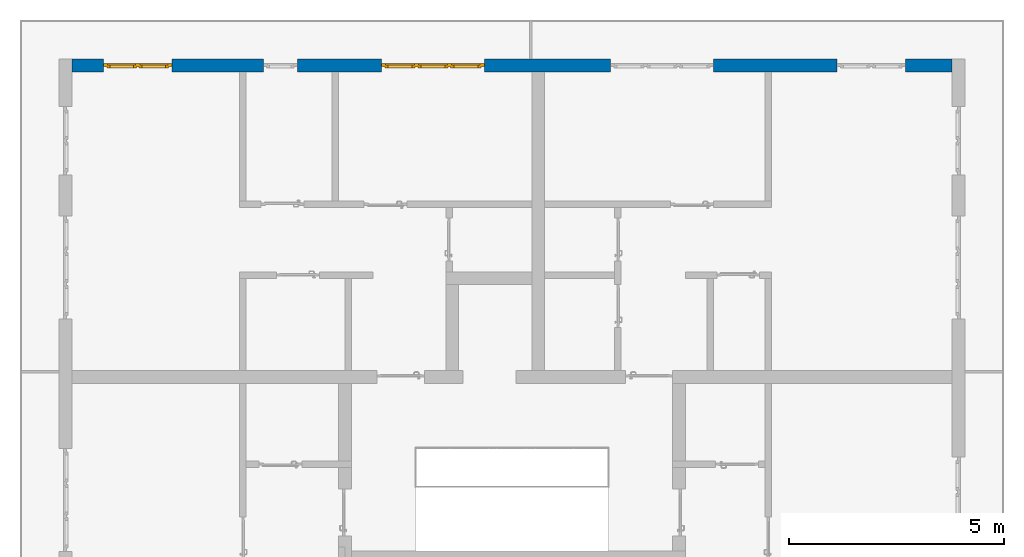
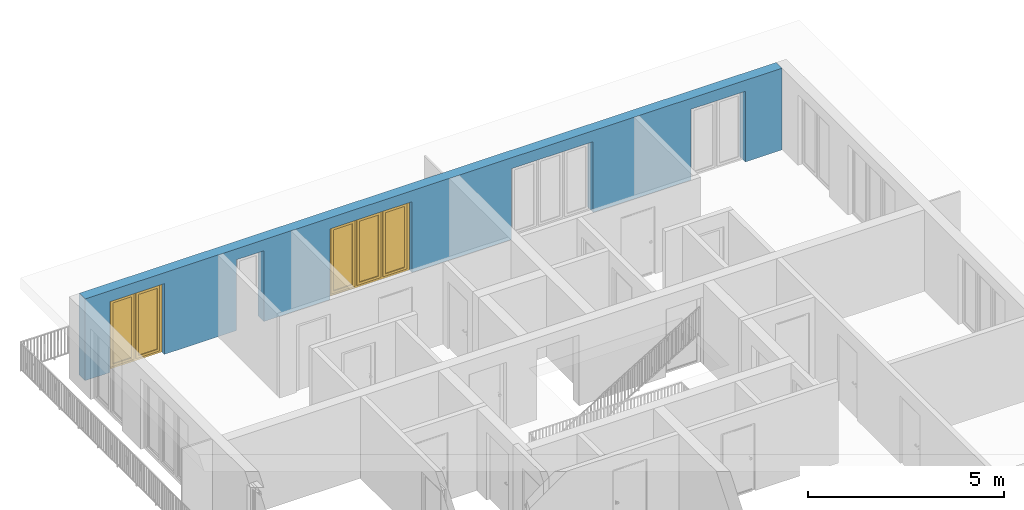
# One storey, part 26 of 54: 2 windows, 1 wall, 5 openings.
"""IFC4 building model written with IfcOpenShell, lengths in metres."""

from ifc_helpers import new_model, entity, si_unit, converted_unit, derived_unit, direction, frame, origin_with_axes, place, context, subcontext, project, spatial, polygons, source, transform, mapped, material, type_object, element, fill, save


model = new_model("IFC4")

# Units and contexts
model_context = context("Model", 3, precision=1e-05, world=origin_with_axes(), true_north=direction((0.0, 1.0)))
body_context = subcontext(model_context, "Body", "Model", "MODEL_VIEW")
ifc_project = project(units=[si_unit("LENGTHUNIT", "METRE"), si_unit("AREAUNIT", "SQUARE_METRE"), si_unit("VOLUMEUNIT", "CUBIC_METRE"), converted_unit("PLANEANGLEUNIT", "DEGREE", entity("IfcPlaneAngleMeasure", 0.0174532925199), si_unit("PLANEANGLEUNIT", "RADIAN"), dimensions=[0, 0, 0, 0, 0, 0, 0]), converted_unit("TIMEUNIT", "Year", entity("IfcTimeMeasure", 31556926.0), si_unit("TIMEUNIT", "SECOND"), dimensions=[0, 0, 1, 0, 0, 0, 0]), si_unit("MASSUNIT", "GRAM", prefix="KILO"), si_unit("THERMODYNAMICTEMPERATUREUNIT", "DEGREE_CELSIUS"), si_unit("LUMINOUSINTENSITYUNIT", "LUMEN"), si_unit("ENERGYUNIT", "JOULE", prefix="MEGA"), derived_unit("THERMALCONDUCTANCEUNIT", [(si_unit("POWERUNIT", "WATT"), 1), (si_unit("LENGTHUNIT", "METRE"), -1), (si_unit("THERMODYNAMICTEMPERATUREUNIT", "KELVIN"), -1)]), derived_unit("SPECIFICHEATCAPACITYUNIT", [(si_unit("ENERGYUNIT", "JOULE"), 1), (si_unit("MASSUNIT", "GRAM", prefix="KILO"), -1), (si_unit("THERMODYNAMICTEMPERATUREUNIT", "KELVIN"), -1)]), derived_unit("MASSDENSITYUNIT", [(si_unit("MASSUNIT", "GRAM", prefix="KILO"), 1), (si_unit("VOLUMEUNIT", "CUBIC_METRE"), -1)])], contexts=[model_context])

# Site, building, storey
site_placement = place(None, origin_with_axes())
site = spatial("IfcSite", under=ifc_project, at=site_placement, CompositionType="ELEMENT")
building_placement = place(site_placement, origin_with_axes())
building = spatial("IfcBuilding", under=site, at=building_placement, CompositionType="ELEMENT")
storey_placement = place(building_placement, frame((0.0, 0.0, 6.29), z_axis=(0.0, 0.0, 1.0), x_axis=(1.0, 0.0, 0.0)))
storey = spatial("IfcBuildingStorey", under=building, at=storey_placement, Name="2. Geschoss", CompositionType="ELEMENT", Elevation=6.29)

# Wall, openings, windows
ifc_material = material()
wall_type = type_object("IfcWallType", Name="300", PredefinedType="NOTDEFINED")
wall_placement = place(storey_placement, frame((-11.7421993804, 8.92118776896, 0.0), z_axis=(0.0, 0.0, 1.0), x_axis=(1.0, 0.0, 0.0)))
wall = element("IfcWall", 1, at=wall_placement, inside=storey, type_object=wall_type, material=ifc_material, Name="Wand-001", PredefinedType="NOTDEFINED", context=body_context, shape_type="Tessellation", body=[
    polygons([(15.23, -0.1, 0.0), (15.23, -0.3, 0.0), (15.23, -0.3, 2.2), (15.23, 0.0, 2.2), (15.23, 0.0, 0.0), (18.102139809, 0.0, 0.0), (18.102139809, -0.3, 0.0), (18.102139809, -0.3, 2.2), (19.702139809, -0.3, 2.2), (19.702139809, -0.3, 0.0), (20.78, -0.3, 0.0), (20.78, -0.3, 2.54), (0.3, -0.3, 2.54), (0.3, -0.3, 0.0), (1.0288518641, -0.3, 0.0), (1.0288518641, -0.3, 2.2), (2.6288518641, -0.3, 2.2), (2.6288518641, -0.3, 0.0), (4.75, -0.3, 0.0), (4.75, -0.3, 2.2), (5.55, -0.3, 2.2), (5.55, -0.3, 0.0), (7.50089858046, -0.3, 0.0), (7.50089858046, -0.3, 2.2), (9.90089858046, -0.3, 2.2), (9.90089858046, -0.3, 0.0), (12.83, -0.3, 0.0), (12.83, -0.3, 2.2), (12.83, 0.0, 2.2), (12.83, 0.0, 0.0), (9.90089858046, 0.0, 0.0), (9.90089858046, 0.0, 2.2), (7.50089858046, 0.0, 2.2), (7.50089858046, 0.0, 0.0), (5.55, 0.0, 0.0), (5.55, 0.0, 2.2), (4.75, 0.0, 2.2), (4.75, 0.0, 0.0), (2.6288518641, 0.0, 0.0), (2.6288518641, 0.0, 2.2), (1.0288518641, 0.0, 2.2), (1.0288518641, 0.0, 0.0), (0.3, 0.0, 0.0), (0.3, 0.0, 2.54), (20.78, 0.0, 2.54), (20.78, 0.0, 0.0), (19.702139809, 0.0, 0.0), (19.702139809, 0.0, 2.2), (18.102139809, 0.0, 2.2), (12.83, -0.1, 0.0)], [[[1, 2, 3, 4, 5]], [[2, 1, 5, 6, 7]], [[3, 2, 7, 8, 9, 10, 11, 12, 13, 14, 15, 16, 17, 18, 19, 20, 21, 22, 23, 24, 25, 26, 27, 28]], [[4, 3, 28, 29]], [[6, 5, 4, 29, 30, 31, 32, 33, 34, 35, 36, 37, 38, 39, 40, 41, 42, 43, 44, 45, 46, 47, 48, 49]], [[6, 49, 8, 7]], [[8, 49, 48, 9]], [[48, 47, 10, 9]], [[46, 11, 10, 47]], [[12, 11, 46, 45]], [[45, 44, 13, 12]], [[44, 43, 14, 13]], [[15, 14, 43, 42]], [[16, 15, 42, 41]], [[40, 17, 16, 41]], [[18, 17, 40, 39]], [[19, 18, 39, 38]], [[20, 19, 38, 37]], [[36, 21, 20, 37]], [[22, 21, 36, 35]], [[22, 35, 34, 23]], [[34, 33, 24, 23]], [[24, 33, 32, 25]], [[32, 31, 26, 25]], [[50, 27, 26, 31, 30]], [[28, 27, 50, 30, 29]]], closed=True),
])
opening_1_placement = place(wall_placement, frame((1.8288518641, 0.0, 0.0), z_axis=(0.0, 0.0, 1.0), x_axis=(1.0, 0.0, 0.0)))
opening_1 = element("IfcOpeningElement", 2, at=opening_1_placement, cuts=wall, Name="Fenster-001", context=body_context, identifier="Reference", shape_type="Tessellation", body=[
    polygons([(-0.8, -0.1, 0.0), (-0.8, -0.1, 2.2), (-0.8, 0.000999999999998, 2.2), (-0.8, 0.000999999999998, 0.0), (-0.8, -0.301, 0.0), (-0.8, -0.301, 2.2), (0.8, -0.1, 2.2), (0.8, 0.000999999999999, 2.2), (0.8, -0.301, 2.2), (0.8, 0.000999999999999, 0.0), (0.8, -0.1, 0.0), (0.8, -0.301, 0.0)], [[[1, 2, 3, 4]], [[2, 1, 5, 6]], [[7, 8, 3, 2, 6, 9]], [[8, 10, 4, 3]], [[1, 4, 10, 11, 12, 5]], [[6, 5, 12, 9]], [[7, 11, 10, 8]], [[11, 7, 9, 12]]], closed=True),
])
opening_2_placement = place(wall_placement, frame((8.70089858046, 0.0, 0.0), z_axis=(0.0, 0.0, 1.0), x_axis=(1.0, 0.0, 0.0)))
opening_2 = element("IfcOpeningElement", 3, at=opening_2_placement, cuts=wall, Name="Fenster-002", context=body_context, identifier="Reference", shape_type="Tessellation", body=[
    polygons([(-1.2, -0.1, 0.0), (-1.2, -0.1, 2.2), (-1.2, 0.000999999999999, 2.2), (-1.2, 0.000999999999999, 0.0), (-1.2, -0.301, 0.0), (-1.2, -0.301, 2.2), (1.2, -0.1, 2.2), (1.2, 0.001, 2.2), (1.2, -0.301, 2.2), (1.2, 0.001, 0.0), (1.2, -0.1, 0.0), (1.2, -0.301, 0.0)], [[[1, 2, 3, 4]], [[2, 1, 5, 6]], [[7, 8, 3, 2, 6, 9]], [[8, 10, 4, 3]], [[1, 4, 10, 11, 12, 5]], [[6, 5, 12, 9]], [[7, 11, 10, 8]], [[11, 7, 9, 12]]], closed=True),
])
opening_3_placement = place(wall_placement, frame((5.15, 0.0, 0.0), z_axis=(0.0, 0.0, 1.0), x_axis=(1.0, 0.0, 0.0)))
element("IfcOpeningElement", 4, at=opening_3_placement, cuts=wall, Name="Fenster-003", context=body_context, identifier="Reference", shape_type="Tessellation", body=[
    polygons([(-0.4, -0.1, 0.0), (-0.4, -0.1, 2.2), (-0.4, 0.001, 2.2), (-0.4, 0.001, 0.0), (-0.4, -0.301, 0.0), (-0.4, -0.301, 2.2), (0.4, -0.1, 2.2), (0.4, 0.001, 2.2), (0.4, -0.301, 2.2), (0.4, 0.001, 0.0), (0.4, -0.1, 0.0), (0.4, -0.301, 0.0)], [[[1, 2, 3, 4]], [[2, 1, 5, 6]], [[7, 8, 3, 2, 6, 9]], [[8, 10, 4, 3]], [[1, 4, 10, 11, 12, 5]], [[6, 5, 12, 9]], [[7, 11, 10, 8]], [[11, 7, 9, 12]]], closed=True),
])
opening_4_placement = place(wall_placement, frame((18.902139809, 0.0, 0.0), z_axis=(0.0, 0.0, 1.0), x_axis=(1.0, 0.0, 0.0)))
element("IfcOpeningElement", 5, at=opening_4_placement, cuts=wall, Name="Fenster-001", context=body_context, identifier="Reference", shape_type="Tessellation", body=[
    polygons([(-0.8, -0.1, 0.0), (-0.8, -0.1, 2.2), (-0.8, 0.001, 2.2), (-0.8, 0.001, 0.0), (-0.8, -0.301, 0.0), (-0.8, -0.301, 2.2), (0.8, -0.1, 2.2), (0.8, 0.001, 2.2), (0.8, -0.301, 2.2), (0.8, 0.001, 0.0), (0.8, -0.1, 0.0), (0.8, -0.301, 0.0)], [[[1, 2, 3, 4]], [[2, 1, 5, 6]], [[7, 8, 3, 2, 6, 9]], [[8, 10, 4, 3]], [[1, 4, 10, 11, 12, 5]], [[6, 5, 12, 9]], [[7, 11, 10, 8]], [[11, 7, 9, 12]]], closed=True),
])
opening_5_placement = place(wall_placement, frame((14.03, 0.0, 0.0), z_axis=(0.0, 0.0, 1.0), x_axis=(1.0, 0.0, 0.0)))
element("IfcOpeningElement", 6, at=opening_5_placement, cuts=wall, Name="Fenster-002", context=body_context, identifier="Reference", shape_type="Tessellation", body=[
    polygons([(-1.2, -0.1, 0.0), (-1.2, -0.1, 2.2), (-1.2, 0.001, 2.2), (-1.2, 0.001, 0.0), (-1.2, -0.301, 0.0), (-1.2, -0.301, 2.2), (1.2, -0.1, 2.2), (1.2, 0.001, 2.2), (1.2, -0.301, 2.2), (1.2, 0.001, 0.0), (1.2, -0.1, 0.0), (1.2, -0.301, 0.0)], [[[1, 2, 3, 4]], [[2, 1, 5, 6]], [[7, 8, 3, 2, 6, 9]], [[8, 10, 4, 3]], [[1, 4, 10, 11, 12, 5]], [[6, 5, 12, 9]], [[7, 11, 10, 8]], [[11, 7, 9, 12]]], closed=True),
])
window_type_1 = type_object("IfcWindowType", Name="2-1+1 26", PartitioningType="DOUBLE_PANEL_VERTICAL", PredefinedType="WINDOW")
shared_shape_1 = source(origin_with_axes(), body_context, "Body", "Tessellation", [
    polygons([(0.8, -0.07, 0.0), (0.7, -0.07, 0.1), (0.7, 0.0, 0.1), (0.8, 0.0, 0.0), (0.8, -0.07, 2.2), (0.7, -0.07, 2.1), (0.7, 0.0, 2.1), (0.8, 0.0, 2.2)], [[[1, 2, 3, 4]], [[1, 5, 6, 2]], [[2, 6, 7, 3]], [[4, 3, 7, 8]], [[5, 1, 4, 8]], [[6, 5, 8, 7]]], closed=True),
    polygons([(-0.8, -0.07, 0.0), (-0.8, -0.07, 2.2), (-0.8, 0.0, 2.2), (-0.8, 0.0, 0.0), (-0.7, -0.07, 0.1), (-0.7, -0.07, 2.1), (-0.7, 0.0, 2.1), (-0.7, 0.0, 0.1)], [[[1, 2, 3, 4]], [[1, 5, 6, 2]], [[2, 6, 7, 3]], [[4, 3, 7, 8]], [[5, 1, 4, 8]], [[6, 5, 8, 7]]], closed=True),
    polygons([(0.8, -0.07, 0.0), (-0.8, -0.07, 0.0), (-0.8, 0.0, 0.0), (0.8, 0.0, 0.0), (0.7, -0.07, 0.1), (0.05, -0.07, 0.1), (-0.05, -0.07, 0.1), (-0.7, -0.07, 0.1), (-0.7, 0.0, 0.1), (-0.05, 0.0, 0.1), (0.05, 0.0, 0.1), (0.7, 0.0, 0.1)], [[[1, 2, 3, 4]], [[1, 5, 6, 7, 8, 2]], [[2, 8, 9, 3]], [[4, 3, 9, 10, 11, 12]], [[5, 1, 4, 12]], [[6, 5, 12, 11]], [[7, 6, 11, 10]], [[8, 7, 10, 9]]], closed=True),
    polygons([(0.8, -0.07, 2.2), (0.7, -0.07, 2.1), (0.7, 0.0, 2.1), (0.8, 0.0, 2.2), (-0.8, -0.07, 2.2), (-0.7, -0.07, 2.1), (-0.05, -0.07, 2.1), (0.05, -0.07, 2.1), (0.05, 0.0, 2.1), (-0.05, 0.0, 2.1), (-0.7, 0.0, 2.1), (-0.8, 0.0, 2.2)], [[[1, 2, 3, 4]], [[1, 5, 6, 7, 8, 2]], [[2, 8, 9, 3]], [[4, 3, 9, 10, 11, 12]], [[5, 1, 4, 12]], [[6, 5, 12, 11]], [[7, 6, 11, 10]], [[8, 7, 10, 9]]], closed=True),
    polygons([(0.05, -0.07, 0.1), (-0.05, -0.07, 0.1), (-0.05, 0.0, 0.1), (0.05, 0.0, 0.1), (0.05, -0.07, 2.1), (-0.05, -0.07, 2.1), (-0.05, 0.0, 2.1), (0.05, 0.0, 2.1)], [[[1, 2, 3, 4]], [[1, 5, 6, 2]], [[2, 6, 7, 3]], [[4, 3, 7, 8]], [[5, 1, 4, 8]], [[6, 5, 8, 7]]], closed=True),
    polygons([(0.72, 0.0, 0.08), (0.65, 0.0, 0.15), (0.65, 0.03, 0.15), (0.72, 0.03, 0.08), (0.72, 0.0, 2.12), (0.65, 0.0, 2.05), (0.65, 0.03, 2.05), (0.72, 0.03, 2.12)], [[[1, 2, 3, 4]], [[1, 5, 6, 2]], [[2, 6, 7, 3]], [[4, 3, 7, 8]], [[5, 1, 4, 8]], [[6, 5, 8, 7]]], closed=True),
    polygons([(0.03, 0.0, 0.08), (0.03, 0.03, 0.08), (0.1, 0.03, 0.15), (0.1, 0.0, 0.15), (0.03, 0.0, 2.12), (0.03, 0.03, 2.12), (0.1, 0.03, 2.05), (0.1, 0.0, 2.05)], [[[1, 2, 3, 4]], [[5, 6, 2, 1]], [[2, 6, 7, 3]], [[4, 3, 7, 8]], [[1, 4, 8, 5]], [[8, 7, 6, 5]]], closed=True),
    polygons([(0.72, 0.0, 0.08), (0.03, 0.0, 0.08), (0.03, 0.03, 0.08), (0.72, 0.03, 0.08), (0.65, 0.0, 0.15), (0.1, 0.0, 0.15), (0.1, 0.03, 0.15), (0.65, 0.03, 0.15)], [[[1, 2, 3, 4]], [[1, 5, 6, 2]], [[2, 6, 7, 3]], [[4, 3, 7, 8]], [[5, 1, 4, 8]], [[6, 5, 8, 7]]], closed=True),
    polygons([(0.72, 0.0, 2.12), (0.72, 0.03, 2.12), (0.03, 0.03, 2.12), (0.03, 0.0, 2.12), (0.65, 0.0, 2.05), (0.65, 0.03, 2.05), (0.1, 0.03, 2.05), (0.1, 0.0, 2.05)], [[[1, 2, 3, 4]], [[5, 6, 2, 1]], [[2, 6, 7, 3]], [[4, 3, 7, 8]], [[1, 4, 8, 5]], [[8, 7, 6, 5]]], closed=True),
    polygons([(0.7, -0.03, 0.1), (0.65, -0.03, 0.15), (0.65, 0.0, 0.15), (0.7, 0.0, 0.1), (0.7, -0.03, 2.1), (0.65, -0.03, 2.05), (0.65, 0.0, 2.05), (0.7, 0.0, 2.1)], [[[1, 2, 3, 4]], [[1, 5, 6, 2]], [[2, 6, 7, 3]], [[4, 3, 7, 8]], [[5, 1, 4, 8]], [[6, 5, 8, 7]]], closed=True),
    polygons([(0.05, -0.03, 0.1), (0.05, 0.0, 0.1), (0.1, 0.0, 0.15), (0.1, -0.03, 0.15), (0.05, -0.03, 2.1), (0.05, 0.0, 2.1), (0.1, 0.0, 2.05), (0.1, -0.03, 2.05)], [[[1, 2, 3, 4]], [[5, 6, 2, 1]], [[2, 6, 7, 3]], [[4, 3, 7, 8]], [[1, 4, 8, 5]], [[8, 7, 6, 5]]], closed=True),
    polygons([(0.7, -0.03, 0.1), (0.05, -0.03, 0.1), (0.05, 0.0, 0.1), (0.7, 0.0, 0.1), (0.65, -0.03, 0.15), (0.1, -0.03, 0.15), (0.1, 0.0, 0.15), (0.65, 0.0, 0.15)], [[[1, 2, 3, 4]], [[1, 5, 6, 2]], [[2, 6, 7, 3]], [[4, 3, 7, 8]], [[5, 1, 4, 8]], [[6, 5, 8, 7]]], closed=True),
    polygons([(0.7, -0.03, 2.1), (0.7, 0.0, 2.1), (0.05, 0.0, 2.1), (0.05, -0.03, 2.1), (0.65, -0.03, 2.05), (0.65, 0.0, 2.05), (0.1, 0.0, 2.05), (0.1, -0.03, 2.05)], [[[1, 2, 3, 4]], [[5, 6, 2, 1]], [[2, 6, 7, 3]], [[4, 3, 7, 8]], [[1, 4, 8, 5]], [[8, 7, 6, 5]]], closed=True),
    polygons([(0.65, -0.005, 0.15), (0.1, -0.005, 0.15), (0.1, 0.005, 0.15), (0.65, 0.005, 0.15), (0.65, -0.005, 2.05), (0.1, -0.005, 2.05), (0.1, 0.005, 2.05), (0.65, 0.005, 2.05)], [[[1, 2, 3, 4]], [[1, 5, 6, 2]], [[2, 6, 7, 3]], [[4, 3, 7, 8]], [[5, 1, 4, 8]], [[6, 5, 8, 7]]], closed=True),
    polygons([(-0.03, 0.0, 0.08), (-0.1, 0.0, 0.15), (-0.1, 0.03, 0.15), (-0.03, 0.03, 0.08), (-0.03, 0.0, 2.12), (-0.1, 0.0, 2.05), (-0.1, 0.03, 2.05), (-0.03, 0.03, 2.12)], [[[1, 2, 3, 4]], [[1, 5, 6, 2]], [[2, 6, 7, 3]], [[4, 3, 7, 8]], [[5, 1, 4, 8]], [[6, 5, 8, 7]]], closed=True),
    polygons([(-0.72, 0.0, 0.08), (-0.72, 0.03, 0.08), (-0.65, 0.03, 0.15), (-0.65, 0.0, 0.15), (-0.72, 0.0, 2.12), (-0.72, 0.03, 2.12), (-0.65, 0.03, 2.05), (-0.65, 0.0, 2.05)], [[[1, 2, 3, 4]], [[5, 6, 2, 1]], [[2, 6, 7, 3]], [[4, 3, 7, 8]], [[1, 4, 8, 5]], [[8, 7, 6, 5]]], closed=True),
    polygons([(-0.03, 0.0, 0.08), (-0.72, 0.0, 0.08), (-0.72, 0.03, 0.08), (-0.03, 0.03, 0.08), (-0.1, 0.0, 0.15), (-0.65, 0.0, 0.15), (-0.65, 0.03, 0.15), (-0.1, 0.03, 0.15)], [[[1, 2, 3, 4]], [[1, 5, 6, 2]], [[2, 6, 7, 3]], [[4, 3, 7, 8]], [[5, 1, 4, 8]], [[6, 5, 8, 7]]], closed=True),
    polygons([(-0.03, 0.0, 2.12), (-0.03, 0.03, 2.12), (-0.72, 0.03, 2.12), (-0.72, 0.0, 2.12), (-0.1, 0.0, 2.05), (-0.1, 0.03, 2.05), (-0.65, 0.03, 2.05), (-0.65, 0.0, 2.05)], [[[1, 2, 3, 4]], [[5, 6, 2, 1]], [[2, 6, 7, 3]], [[4, 3, 7, 8]], [[1, 4, 8, 5]], [[8, 7, 6, 5]]], closed=True),
    polygons([(-0.05, -0.03, 0.1), (-0.1, -0.03, 0.15), (-0.1, 0.0, 0.15), (-0.05, 0.0, 0.1), (-0.05, -0.03, 2.1), (-0.1, -0.03, 2.05), (-0.1, 0.0, 2.05), (-0.05, 0.0, 2.1)], [[[1, 2, 3, 4]], [[1, 5, 6, 2]], [[2, 6, 7, 3]], [[4, 3, 7, 8]], [[5, 1, 4, 8]], [[6, 5, 8, 7]]], closed=True),
    polygons([(-0.7, -0.03, 0.1), (-0.7, 0.0, 0.1), (-0.65, 0.0, 0.15), (-0.65, -0.03, 0.15), (-0.7, -0.03, 2.1), (-0.7, 0.0, 2.1), (-0.65, 0.0, 2.05), (-0.65, -0.03, 2.05)], [[[1, 2, 3, 4]], [[5, 6, 2, 1]], [[2, 6, 7, 3]], [[4, 3, 7, 8]], [[1, 4, 8, 5]], [[8, 7, 6, 5]]], closed=True),
    polygons([(-0.05, -0.03, 0.1), (-0.7, -0.03, 0.1), (-0.7, 0.0, 0.1), (-0.05, 0.0, 0.1), (-0.1, -0.03, 0.15), (-0.65, -0.03, 0.15), (-0.65, 0.0, 0.15), (-0.1, 0.0, 0.15)], [[[1, 2, 3, 4]], [[1, 5, 6, 2]], [[2, 6, 7, 3]], [[4, 3, 7, 8]], [[5, 1, 4, 8]], [[6, 5, 8, 7]]], closed=True),
    polygons([(-0.05, -0.03, 2.1), (-0.05, 0.0, 2.1), (-0.7, 0.0, 2.1), (-0.7, -0.03, 2.1), (-0.1, -0.03, 2.05), (-0.1, 0.0, 2.05), (-0.65, 0.0, 2.05), (-0.65, -0.03, 2.05)], [[[1, 2, 3, 4]], [[5, 6, 2, 1]], [[2, 6, 7, 3]], [[4, 3, 7, 8]], [[1, 4, 8, 5]], [[8, 7, 6, 5]]], closed=True),
    polygons([(-0.1, -0.005, 0.15), (-0.65, -0.005, 0.15), (-0.65, 0.005, 0.15), (-0.1, 0.005, 0.15), (-0.1, -0.005, 2.05), (-0.65, -0.005, 2.05), (-0.65, 0.005, 2.05), (-0.1, 0.005, 2.05)], [[[1, 2, 3, 4]], [[1, 5, 6, 2]], [[2, 6, 7, 3]], [[4, 3, 7, 8]], [[5, 1, 4, 8]], [[6, 5, 8, 7]]], closed=True),
])
window_1_placement = place(opening_1_placement, frame((0.8, 0.0, 0.0), z_axis=(0.0, 0.0, 1.0), x_axis=(-1.0, 0.0, 0.0)))
window_1 = element("IfcWindow", 7, at=window_1_placement, inside=storey, type_object=window_type_1, Name="Fenster-001", OverallHeight=2.2, OverallWidth=1.6, PredefinedType="WINDOW", context=body_context, shape_type="MappedRepresentation", body=[
    mapped(shared_shape_1, transform((0.8, 0.17, 0.0))),
])
fill(opening_1, window_1)
window_type_2 = type_object("IfcWindowType", Name="3-1+1+1 26", PartitioningType="TRIPLE_PANEL_VERTICAL", PredefinedType="WINDOW")
shared_shape_2 = source(origin_with_axes(), body_context, "Body", "Tessellation", [
    polygons([(1.2, -0.07, 0.0), (1.1, -0.07, 0.1), (1.1, 0.0, 0.1), (1.2, 0.0, 0.0), (1.2, -0.07, 2.2), (1.1, -0.07, 2.1), (1.1, 0.0, 2.1), (1.2, 0.0, 2.2)], [[[1, 2, 3, 4]], [[1, 5, 6, 2]], [[2, 6, 7, 3]], [[4, 3, 7, 8]], [[5, 1, 4, 8]], [[6, 5, 8, 7]]], closed=True),
    polygons([(-1.2, -0.07, 0.0), (-1.2, -0.07, 2.2), (-1.2, 0.0, 2.2), (-1.2, 0.0, 0.0), (-1.1, -0.07, 0.1), (-1.1, -0.07, 2.1), (-1.1, 0.0, 2.1), (-1.1, 0.0, 0.1)], [[[1, 2, 3, 4]], [[1, 5, 6, 2]], [[2, 6, 7, 3]], [[4, 3, 7, 8]], [[5, 1, 4, 8]], [[6, 5, 8, 7]]], closed=True),
    polygons([(1.2, -0.07, 0.0), (-1.2, -0.07, 0.0), (-1.2, 0.0, 0.0), (1.2, 0.0, 0.0), (1.1, -0.07, 0.1), (0.433333333333, -0.07, 0.1), (0.333333333333, -0.07, 0.1), (-0.333333333333, -0.07, 0.1), (-0.433333333333, -0.07, 0.1), (-1.1, -0.07, 0.1), (-1.1, 0.0, 0.1), (-0.433333333333, 0.0, 0.1), (-0.333333333333, 0.0, 0.1), (0.333333333333, 0.0, 0.1), (0.433333333333, 0.0, 0.1), (1.1, 0.0, 0.1)], [[[1, 2, 3, 4]], [[1, 5, 6, 7, 8, 9, 10, 2]], [[2, 10, 11, 3]], [[4, 3, 11, 12, 13, 14, 15, 16]], [[5, 1, 4, 16]], [[6, 5, 16, 15]], [[7, 6, 15, 14]], [[8, 7, 14, 13]], [[9, 8, 13, 12]], [[10, 9, 12, 11]]], closed=True),
    polygons([(1.2, -0.07, 2.2), (1.1, -0.07, 2.1), (1.1, 0.0, 2.1), (1.2, 0.0, 2.2), (-1.2, -0.07, 2.2), (-1.1, -0.07, 2.1), (-0.433333333333, -0.07, 2.1), (-0.333333333333, -0.07, 2.1), (0.333333333333, -0.07, 2.1), (0.433333333333, -0.07, 2.1), (0.433333333333, 0.0, 2.1), (0.333333333333, 0.0, 2.1), (-0.333333333333, 0.0, 2.1), (-0.433333333333, 0.0, 2.1), (-1.1, 0.0, 2.1), (-1.2, 0.0, 2.2)], [[[1, 2, 3, 4]], [[1, 5, 6, 7, 8, 9, 10, 2]], [[2, 10, 11, 3]], [[4, 3, 11, 12, 13, 14, 15, 16]], [[5, 1, 4, 16]], [[6, 5, 16, 15]], [[7, 6, 15, 14]], [[8, 7, 14, 13]], [[9, 8, 13, 12]], [[10, 9, 12, 11]]], closed=True),
    polygons([(-0.333333333333, -0.07, 0.1), (-0.433333333333, -0.07, 0.1), (-0.433333333333, 0.0, 0.1), (-0.333333333333, 0.0, 0.1), (-0.333333333333, -0.07, 2.1), (-0.433333333333, -0.07, 2.1), (-0.433333333333, 0.0, 2.1), (-0.333333333333, 0.0, 2.1)], [[[1, 2, 3, 4]], [[1, 5, 6, 2]], [[2, 6, 7, 3]], [[4, 3, 7, 8]], [[5, 1, 4, 8]], [[6, 5, 8, 7]]], closed=True),
    polygons([(0.433333333333, -0.07, 0.1), (0.333333333333, -0.07, 0.1), (0.333333333333, 0.0, 0.1), (0.433333333333, 0.0, 0.1), (0.433333333333, -0.07, 2.1), (0.333333333333, -0.07, 2.1), (0.333333333333, 0.0, 2.1), (0.433333333333, 0.0, 2.1)], [[[1, 2, 3, 4]], [[1, 5, 6, 2]], [[2, 6, 7, 3]], [[4, 3, 7, 8]], [[5, 1, 4, 8]], [[6, 5, 8, 7]]], closed=True),
    polygons([(1.12, 0.0, 0.08), (1.05, 0.0, 0.15), (1.05, 0.03, 0.15), (1.12, 0.03, 0.08), (1.12, 0.0, 2.12), (1.05, 0.0, 2.05), (1.05, 0.03, 2.05), (1.12, 0.03, 2.12)], [[[1, 2, 3, 4]], [[1, 5, 6, 2]], [[2, 6, 7, 3]], [[4, 3, 7, 8]], [[5, 1, 4, 8]], [[6, 5, 8, 7]]], closed=True),
    polygons([(0.413333333333, 0.0, 0.08), (0.413333333333, 0.03, 0.08), (0.483333333333, 0.03, 0.15), (0.483333333333, 0.0, 0.15), (0.413333333333, 0.0, 2.12), (0.413333333333, 0.03, 2.12), (0.483333333333, 0.03, 2.05), (0.483333333333, 0.0, 2.05)], [[[1, 2, 3, 4]], [[5, 6, 2, 1]], [[2, 6, 7, 3]], [[4, 3, 7, 8]], [[1, 4, 8, 5]], [[8, 7, 6, 5]]], closed=True),
    polygons([(1.12, 0.0, 0.08), (0.413333333333, 0.0, 0.08), (0.413333333333, 0.03, 0.08), (1.12, 0.03, 0.08), (1.05, 0.0, 0.15), (0.483333333333, 0.0, 0.15), (0.483333333333, 0.03, 0.15), (1.05, 0.03, 0.15)], [[[1, 2, 3, 4]], [[1, 5, 6, 2]], [[2, 6, 7, 3]], [[4, 3, 7, 8]], [[5, 1, 4, 8]], [[6, 5, 8, 7]]], closed=True),
    polygons([(1.12, 0.0, 2.12), (1.12, 0.03, 2.12), (0.413333333333, 0.03, 2.12), (0.413333333333, 0.0, 2.12), (1.05, 0.0, 2.05), (1.05, 0.03, 2.05), (0.483333333333, 0.03, 2.05), (0.483333333333, 0.0, 2.05)], [[[1, 2, 3, 4]], [[5, 6, 2, 1]], [[2, 6, 7, 3]], [[4, 3, 7, 8]], [[1, 4, 8, 5]], [[8, 7, 6, 5]]], closed=True),
    polygons([(1.1, -0.03, 0.1), (1.05, -0.03, 0.15), (1.05, 0.0, 0.15), (1.1, 0.0, 0.1), (1.1, -0.03, 2.1), (1.05, -0.03, 2.05), (1.05, 0.0, 2.05), (1.1, 0.0, 2.1)], [[[1, 2, 3, 4]], [[1, 5, 6, 2]], [[2, 6, 7, 3]], [[4, 3, 7, 8]], [[5, 1, 4, 8]], [[6, 5, 8, 7]]], closed=True),
    polygons([(0.433333333333, -0.03, 0.1), (0.433333333333, 0.0, 0.1), (0.483333333333, 0.0, 0.15), (0.483333333333, -0.03, 0.15), (0.433333333333, -0.03, 2.1), (0.433333333333, 0.0, 2.1), (0.483333333333, 0.0, 2.05), (0.483333333333, -0.03, 2.05)], [[[1, 2, 3, 4]], [[5, 6, 2, 1]], [[2, 6, 7, 3]], [[4, 3, 7, 8]], [[1, 4, 8, 5]], [[8, 7, 6, 5]]], closed=True),
    polygons([(1.1, -0.03, 0.1), (0.433333333333, -0.03, 0.1), (0.433333333333, 0.0, 0.1), (1.1, 0.0, 0.1), (1.05, -0.03, 0.15), (0.483333333333, -0.03, 0.15), (0.483333333333, 0.0, 0.15), (1.05, 0.0, 0.15)], [[[1, 2, 3, 4]], [[1, 5, 6, 2]], [[2, 6, 7, 3]], [[4, 3, 7, 8]], [[5, 1, 4, 8]], [[6, 5, 8, 7]]], closed=True),
    polygons([(1.1, -0.03, 2.1), (1.1, 0.0, 2.1), (0.433333333333, 0.0, 2.1), (0.433333333333, -0.03, 2.1), (1.05, -0.03, 2.05), (1.05, 0.0, 2.05), (0.483333333333, 0.0, 2.05), (0.483333333333, -0.03, 2.05)], [[[1, 2, 3, 4]], [[5, 6, 2, 1]], [[2, 6, 7, 3]], [[4, 3, 7, 8]], [[1, 4, 8, 5]], [[8, 7, 6, 5]]], closed=True),
    polygons([(1.05, -0.005, 0.15), (0.483333333333, -0.005, 0.15), (0.483333333333, 0.005, 0.15), (1.05, 0.005, 0.15), (1.05, -0.005, 2.05), (0.483333333333, -0.005, 2.05), (0.483333333333, 0.005, 2.05), (1.05, 0.005, 2.05)], [[[1, 2, 3, 4]], [[1, 5, 6, 2]], [[2, 6, 7, 3]], [[4, 3, 7, 8]], [[5, 1, 4, 8]], [[6, 5, 8, 7]]], closed=True),
    polygons([(0.353333333333, 0.0, 0.08), (0.283333333333, 0.0, 0.15), (0.283333333333, 0.03, 0.15), (0.353333333333, 0.03, 0.08), (0.353333333333, 0.0, 2.12), (0.283333333333, 0.0, 2.05), (0.283333333333, 0.03, 2.05), (0.353333333333, 0.03, 2.12)], [[[1, 2, 3, 4]], [[1, 5, 6, 2]], [[2, 6, 7, 3]], [[4, 3, 7, 8]], [[5, 1, 4, 8]], [[6, 5, 8, 7]]], closed=True),
    polygons([(-0.353333333333, 0.0, 0.08), (-0.353333333333, 0.03, 0.08), (-0.283333333333, 0.03, 0.15), (-0.283333333333, 0.0, 0.15), (-0.353333333333, 0.0, 2.12), (-0.353333333333, 0.03, 2.12), (-0.283333333333, 0.03, 2.05), (-0.283333333333, 0.0, 2.05)], [[[1, 2, 3, 4]], [[5, 6, 2, 1]], [[2, 6, 7, 3]], [[4, 3, 7, 8]], [[1, 4, 8, 5]], [[8, 7, 6, 5]]], closed=True),
    polygons([(0.353333333333, 0.0, 0.08), (-0.353333333333, 0.0, 0.08), (-0.353333333333, 0.03, 0.08), (0.353333333333, 0.03, 0.08), (0.283333333333, 0.0, 0.15), (-0.283333333333, 0.0, 0.15), (-0.283333333333, 0.03, 0.15), (0.283333333333, 0.03, 0.15)], [[[1, 2, 3, 4]], [[1, 5, 6, 2]], [[2, 6, 7, 3]], [[4, 3, 7, 8]], [[5, 1, 4, 8]], [[6, 5, 8, 7]]], closed=True),
    polygons([(0.353333333333, 0.0, 2.12), (0.353333333333, 0.03, 2.12), (-0.353333333333, 0.03, 2.12), (-0.353333333333, 0.0, 2.12), (0.283333333333, 0.0, 2.05), (0.283333333333, 0.03, 2.05), (-0.283333333333, 0.03, 2.05), (-0.283333333333, 0.0, 2.05)], [[[1, 2, 3, 4]], [[5, 6, 2, 1]], [[2, 6, 7, 3]], [[4, 3, 7, 8]], [[1, 4, 8, 5]], [[8, 7, 6, 5]]], closed=True),
    polygons([(0.333333333333, -0.03, 0.1), (0.283333333333, -0.03, 0.15), (0.283333333333, 0.0, 0.15), (0.333333333333, 0.0, 0.1), (0.333333333333, -0.03, 2.1), (0.283333333333, -0.03, 2.05), (0.283333333333, 0.0, 2.05), (0.333333333333, 0.0, 2.1)], [[[1, 2, 3, 4]], [[1, 5, 6, 2]], [[2, 6, 7, 3]], [[4, 3, 7, 8]], [[5, 1, 4, 8]], [[6, 5, 8, 7]]], closed=True),
    polygons([(-0.333333333333, -0.03, 0.1), (-0.333333333333, 0.0, 0.1), (-0.283333333333, 0.0, 0.15), (-0.283333333333, -0.03, 0.15), (-0.333333333333, -0.03, 2.1), (-0.333333333333, 0.0, 2.1), (-0.283333333333, 0.0, 2.05), (-0.283333333333, -0.03, 2.05)], [[[1, 2, 3, 4]], [[5, 6, 2, 1]], [[2, 6, 7, 3]], [[4, 3, 7, 8]], [[1, 4, 8, 5]], [[8, 7, 6, 5]]], closed=True),
    polygons([(0.333333333333, -0.03, 0.1), (-0.333333333333, -0.03, 0.1), (-0.333333333333, 0.0, 0.1), (0.333333333333, 0.0, 0.1), (0.283333333333, -0.03, 0.15), (-0.283333333333, -0.03, 0.15), (-0.283333333333, 0.0, 0.15), (0.283333333333, 0.0, 0.15)], [[[1, 2, 3, 4]], [[1, 5, 6, 2]], [[2, 6, 7, 3]], [[4, 3, 7, 8]], [[5, 1, 4, 8]], [[6, 5, 8, 7]]], closed=True),
    polygons([(0.333333333333, -0.03, 2.1), (0.333333333333, 0.0, 2.1), (-0.333333333333, 0.0, 2.1), (-0.333333333333, -0.03, 2.1), (0.283333333333, -0.03, 2.05), (0.283333333333, 0.0, 2.05), (-0.283333333333, 0.0, 2.05), (-0.283333333333, -0.03, 2.05)], [[[1, 2, 3, 4]], [[5, 6, 2, 1]], [[2, 6, 7, 3]], [[4, 3, 7, 8]], [[1, 4, 8, 5]], [[8, 7, 6, 5]]], closed=True),
    polygons([(0.283333333333, -0.005, 0.15), (-0.283333333333, -0.005, 0.15), (-0.283333333333, 0.005, 0.15), (0.283333333333, 0.005, 0.15), (0.283333333333, -0.005, 2.05), (-0.283333333333, -0.005, 2.05), (-0.283333333333, 0.005, 2.05), (0.283333333333, 0.005, 2.05)], [[[1, 2, 3, 4]], [[1, 5, 6, 2]], [[2, 6, 7, 3]], [[4, 3, 7, 8]], [[5, 1, 4, 8]], [[6, 5, 8, 7]]], closed=True),
    polygons([(-0.413333333333, 0.0, 0.08), (-0.483333333333, 0.0, 0.15), (-0.483333333333, 0.03, 0.15), (-0.413333333333, 0.03, 0.08), (-0.413333333333, 0.0, 2.12), (-0.483333333333, 0.0, 2.05), (-0.483333333333, 0.03, 2.05), (-0.413333333333, 0.03, 2.12)], [[[1, 2, 3, 4]], [[1, 5, 6, 2]], [[2, 6, 7, 3]], [[4, 3, 7, 8]], [[5, 1, 4, 8]], [[6, 5, 8, 7]]], closed=True),
    polygons([(-1.12, 0.0, 0.08), (-1.12, 0.03, 0.08), (-1.05, 0.03, 0.15), (-1.05, 0.0, 0.15), (-1.12, 0.0, 2.12), (-1.12, 0.03, 2.12), (-1.05, 0.03, 2.05), (-1.05, 0.0, 2.05)], [[[1, 2, 3, 4]], [[5, 6, 2, 1]], [[2, 6, 7, 3]], [[4, 3, 7, 8]], [[1, 4, 8, 5]], [[8, 7, 6, 5]]], closed=True),
    polygons([(-0.413333333333, 0.0, 0.08), (-1.12, 0.0, 0.08), (-1.12, 0.03, 0.08), (-0.413333333333, 0.03, 0.08), (-0.483333333333, 0.0, 0.15), (-1.05, 0.0, 0.15), (-1.05, 0.03, 0.15), (-0.483333333333, 0.03, 0.15)], [[[1, 2, 3, 4]], [[1, 5, 6, 2]], [[2, 6, 7, 3]], [[4, 3, 7, 8]], [[5, 1, 4, 8]], [[6, 5, 8, 7]]], closed=True),
    polygons([(-0.413333333333, 0.0, 2.12), (-0.413333333333, 0.03, 2.12), (-1.12, 0.03, 2.12), (-1.12, 0.0, 2.12), (-0.483333333333, 0.0, 2.05), (-0.483333333333, 0.03, 2.05), (-1.05, 0.03, 2.05), (-1.05, 0.0, 2.05)], [[[1, 2, 3, 4]], [[5, 6, 2, 1]], [[2, 6, 7, 3]], [[4, 3, 7, 8]], [[1, 4, 8, 5]], [[8, 7, 6, 5]]], closed=True),
    polygons([(-0.433333333333, -0.03, 0.1), (-0.483333333333, -0.03, 0.15), (-0.483333333333, 0.0, 0.15), (-0.433333333333, 0.0, 0.1), (-0.433333333333, -0.03, 2.1), (-0.483333333333, -0.03, 2.05), (-0.483333333333, 0.0, 2.05), (-0.433333333333, 0.0, 2.1)], [[[1, 2, 3, 4]], [[1, 5, 6, 2]], [[2, 6, 7, 3]], [[4, 3, 7, 8]], [[5, 1, 4, 8]], [[6, 5, 8, 7]]], closed=True),
    polygons([(-1.1, -0.03, 0.1), (-1.1, 0.0, 0.1), (-1.05, 0.0, 0.15), (-1.05, -0.03, 0.15), (-1.1, -0.03, 2.1), (-1.1, 0.0, 2.1), (-1.05, 0.0, 2.05), (-1.05, -0.03, 2.05)], [[[1, 2, 3, 4]], [[5, 6, 2, 1]], [[2, 6, 7, 3]], [[4, 3, 7, 8]], [[1, 4, 8, 5]], [[8, 7, 6, 5]]], closed=True),
    polygons([(-0.433333333333, -0.03, 0.1), (-1.1, -0.03, 0.1), (-1.1, 0.0, 0.1), (-0.433333333333, 0.0, 0.1), (-0.483333333333, -0.03, 0.15), (-1.05, -0.03, 0.15), (-1.05, 0.0, 0.15), (-0.483333333333, 0.0, 0.15)], [[[1, 2, 3, 4]], [[1, 5, 6, 2]], [[2, 6, 7, 3]], [[4, 3, 7, 8]], [[5, 1, 4, 8]], [[6, 5, 8, 7]]], closed=True),
    polygons([(-0.433333333333, -0.03, 2.1), (-0.433333333333, 0.0, 2.1), (-1.1, 0.0, 2.1), (-1.1, -0.03, 2.1), (-0.483333333333, -0.03, 2.05), (-0.483333333333, 0.0, 2.05), (-1.05, 0.0, 2.05), (-1.05, -0.03, 2.05)], [[[1, 2, 3, 4]], [[5, 6, 2, 1]], [[2, 6, 7, 3]], [[4, 3, 7, 8]], [[1, 4, 8, 5]], [[8, 7, 6, 5]]], closed=True),
    polygons([(-0.483333333333, -0.005, 0.15), (-1.05, -0.005, 0.15), (-1.05, 0.005, 0.15), (-0.483333333333, 0.005, 0.15), (-0.483333333333, -0.005, 2.05), (-1.05, -0.005, 2.05), (-1.05, 0.005, 2.05), (-0.483333333333, 0.005, 2.05)], [[[1, 2, 3, 4]], [[1, 5, 6, 2]], [[2, 6, 7, 3]], [[4, 3, 7, 8]], [[5, 1, 4, 8]], [[6, 5, 8, 7]]], closed=True),
])
window_2_placement = place(opening_2_placement, frame((1.2, 0.0, 0.0), z_axis=(0.0, 0.0, 1.0), x_axis=(-1.0, 0.0, 0.0)))
window_2 = element("IfcWindow", 8, at=window_2_placement, inside=storey, type_object=window_type_2, Name="Fenster-002", OverallHeight=2.2, OverallWidth=2.4, PredefinedType="WINDOW", context=body_context, shape_type="MappedRepresentation", body=[
    mapped(shared_shape_2, transform((1.2, 0.17, 0.0))),
])
fill(opening_2, window_2)

save(model, "model.ifc")
